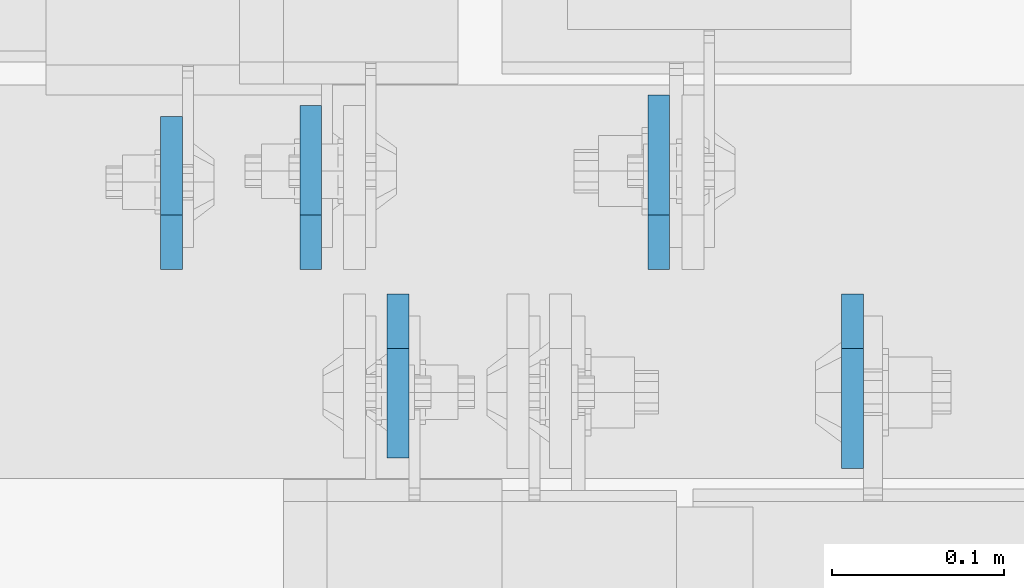
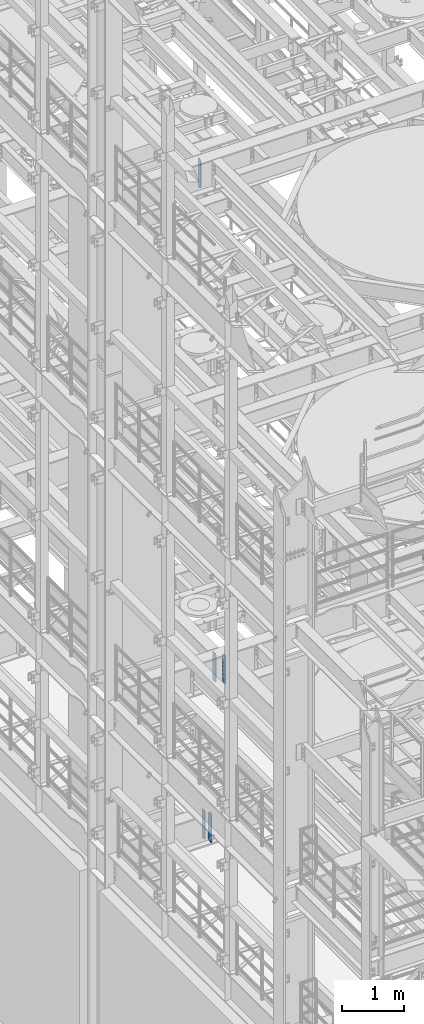
# One storey, part 1562 of 1876: 5 plates, 3 elements without a shape of their own.
"""IFC2X3 building model written with IfcOpenShell, lengths in millimetres."""

from ifc_helpers import new_model, si_unit, frame, origin_with_axes, place, context, subcontext, project, spatial, faceted_brep, material, type_object, element, aggregate, save


model = new_model("IFC2X3")

# Units and contexts
model_context = context("Model", 3, precision=1e-05, world=origin_with_axes())
body_context = subcontext(model_context, "Body", "Model", "MODEL_VIEW")
ifc_project = project(units=[si_unit("LENGTHUNIT", "METRE", prefix="MILLI"), si_unit("AREAUNIT", "SQUARE_METRE"), si_unit("VOLUMEUNIT", "CUBIC_METRE"), si_unit("MASSUNIT", "GRAM", prefix="KILO"), si_unit("TIMEUNIT", "SECOND"), si_unit("PLANEANGLEUNIT", "RADIAN"), si_unit("SOLIDANGLEUNIT", "STERADIAN"), si_unit("THERMODYNAMICTEMPERATUREUNIT", "DEGREE_CELSIUS"), si_unit("LUMINOUSINTENSITYUNIT", "LUMEN")], contexts=[model_context])

# Site, building, storey
site_placement = place(None, origin_with_axes())
site = spatial("IfcSite", under=ifc_project, at=site_placement, CompositionType="ELEMENT")
building_placement = place(site_placement, origin_with_axes())
building = spatial("IfcBuilding", under=site, at=building_placement, Name="Undefined", CompositionType="ELEMENT")
storey_placement = place(building_placement, origin_with_axes())
storey = spatial("IfcBuildingStorey", under=building, at=storey_placement, Name="Undefined", CompositionType="ELEMENT", Elevation=0.0)

# Assembly, plate
assembly_1_placement = place(storey_placement, origin_with_axes())
assembly_1 = element("IfcElementAssembly", 1, at=assembly_1_placement, inside=storey, Name="BEAM", AssemblyPlace="NOTDEFINED", PredefinedType="RIGID_FRAME")
ifc_material = material(Name="STEEL/A36")
plate_type_1 = type_object("IfcPlateType", PredefinedType="NOTDEFINED")
plate_1_placement = place(assembly_1_placement, frame((1789.11249990463, 1531.14375, 17386.3), z_axis=(0.0, 0.0, 1.0), x_axis=(0.0, 1.0, 0.0)))
plate_1 = element("IfcPlate", 2, at=plate_1_placement, type_object=plate_type_1, material=ifc_material, Name="PLATE", context=body_context, shape_type="Brep", body=[
    faceted_brep([(0.0, -6.34999999999991, 31.75), (0.0, -6.34999999999991, 539.75), (0.0, 6.34999999999991, 539.75), (0.0, 6.34999999999991, 31.75), (31.75, -6.34999999999991, 571.5), (31.75, 6.34999999999991, 571.5), (88.9000015258789, -6.34999999999991, 571.5), (88.9000015258789, 6.34999999999991, 571.5), (88.9000015258789, -6.34999999999991, 0.0), (88.9000015258789, 6.34999999999991, 0.0), (31.75, -6.34999999999991, 0.0), (31.75, 6.34999999999991, 0.0)], [[[0, 1, 2, 3]], [[1, 4, 5, 2]], [[4, 6, 7, 5]], [[6, 8, 9, 7]], [[8, 10, 11, 9]], [[10, 0, 3, 11]], [[5, 7, 9, 11, 3, 2]], [[10, 8, 6, 4, 1, 0]]]),
])
aggregate(assembly_1, [plate_1])

# Assembly, plates
assembly_2_placement = place(storey_placement, origin_with_axes())
assembly_2 = element("IfcElementAssembly", 3, at=assembly_2_placement, inside=storey, Name="BEAM", AssemblyPlace="NOTDEFINED", PredefinedType="RIGID_FRAME")
plate_type_2 = type_object("IfcPlateType", PredefinedType="NOTDEFINED")
plate_2_placement = place(assembly_2_placement, frame((1920.875, 1516.85625, 4535.4875), z_axis=(0.0, 0.0, 1.0), x_axis=(0.0, -1.0, 0.0)))
plate_2 = element("IfcPlate", 4, at=plate_2_placement, type_object=plate_type_2, material=ifc_material, Name="PLATE", context=body_context, shape_type="Brep", body=[
    faceted_brep([(0.0, -6.34999999999991, 31.75), (0.0, -6.35000000000036, 538.162475585938), (0.0, 6.35000000000036, 538.162475585938), (0.0, 6.34999999999991, 31.75), (31.75, -6.35000000000036, 569.912475585938), (31.75, 6.35000000000036, 569.912475585938), (95.25, -6.35000000000036, 569.912475585938), (95.25, 6.35000000000036, 569.912475585938), (95.25, -6.35000000000036, 0.0), (95.25, 6.35000000000036, 0.0), (31.75, -6.34999999999991, 0.0), (31.75, 6.34999999999991, 0.0)], [[[0, 1, 2, 3]], [[1, 4, 5, 2]], [[4, 6, 7, 5]], [[6, 8, 9, 7]], [[8, 10, 11, 9]], [[10, 0, 3, 11]], [[5, 7, 9, 11, 3, 2]], [[10, 8, 6, 4, 1, 0]]]),
])
plate_3_placement = place(assembly_2_placement, frame((1870.07499990463, 1531.14375, 4535.4875), z_axis=(0.0, 0.0, 1.0), x_axis=(0.0, 1.0, 0.0)))
plate_3 = element("IfcPlate", 5, at=plate_3_placement, type_object=plate_type_2, material=ifc_material, Name="PLATE", context=body_context, shape_type="Brep", body=[
    faceted_brep([(0.0, -6.34999999999991, 31.75), (0.0, -6.35000000000036, 538.162475585938), (0.0, 6.35000000000036, 538.162475585938), (0.0, 6.34999999999991, 31.75), (31.75, -6.35000000000036, 569.912475585938), (31.75, 6.35000000000036, 569.912475585938), (95.25, -6.35000000000036, 569.912475585938), (95.25, 6.35000000000036, 569.912475585938), (95.25, -6.35000000000036, 0.0), (95.25, 6.35000000000036, 0.0), (31.75, -6.34999999999991, 0.0), (31.75, 6.34999999999991, 0.0)], [[[0, 1, 2, 3]], [[1, 4, 5, 2]], [[4, 6, 7, 5]], [[6, 8, 9, 7]], [[8, 10, 11, 9]], [[10, 0, 3, 11]], [[5, 7, 9, 11, 3, 2]], [[10, 8, 6, 4, 1, 0]]]),
])
aggregate(assembly_2, [plate_2, plate_3])

assembly_3_placement = place(storey_placement, origin_with_axes())
assembly_3 = element("IfcElementAssembly", 6, at=assembly_3_placement, inside=storey, Name="BEAM", AssemblyPlace="NOTDEFINED", PredefinedType="RIGID_FRAME")
plate_type_3 = type_object("IfcPlateType", PredefinedType="NOTDEFINED")
plate_4_placement = place(assembly_3_placement, frame((2185.19374990463, 1516.85625, 7558.0875), z_axis=(0.0, 0.0, 1.0), x_axis=(0.0, -1.0, 0.0)))
plate_4 = element("IfcPlate", 7, at=plate_4_placement, type_object=plate_type_3, material=ifc_material, Name="PLATE", context=body_context, shape_type="Brep", body=[
    faceted_brep([(0.0, -6.34999999999991, 31.75), (0.0, -6.35000000000036, 538.162475585938), (0.0, 6.35000000000036, 538.162475585938), (0.0, 6.34999999999991, 31.75), (31.75, -6.35000000000036, 569.912475585938), (31.75, 6.35000000000036, 569.912475585938), (101.599998474121, -6.34999999999991, 569.912475585938), (101.599998474121, 6.34999999999991, 569.912475585938), (101.599998474121, -6.35000000000036, 0.0), (101.599998474121, 6.35000000000036, 0.0), (31.75, -6.34999999999991, 0.0), (31.75, 6.34999999999991, 0.0)], [[[0, 1, 2, 3]], [[1, 4, 5, 2]], [[4, 6, 7, 5]], [[6, 8, 9, 7]], [[8, 10, 11, 9]], [[10, 0, 3, 11]], [[5, 7, 9, 11, 3, 2]], [[10, 8, 6, 4, 1, 0]]]),
])
plate_5_placement = place(assembly_3_placement, frame((2072.48124990463, 1531.14375, 7558.0875), z_axis=(0.0, 0.0, 1.0), x_axis=(0.0, 1.0, 0.0)))
plate_5 = element("IfcPlate", 8, at=plate_5_placement, type_object=plate_type_3, material=ifc_material, Name="PLATE", context=body_context, shape_type="Brep", body=[
    faceted_brep([(0.0, -6.34999999999991, 31.75), (0.0, -6.35000000000036, 538.162475585938), (0.0, 6.35000000000036, 538.162475585938), (0.0, 6.34999999999991, 31.75), (31.75, -6.35000000000036, 569.912475585938), (31.75, 6.35000000000036, 569.912475585938), (101.599998474121, -6.34999999999991, 569.912475585938), (101.599998474121, 6.34999999999991, 569.912475585938), (101.599998474121, -6.35000000000036, 0.0), (101.599998474121, 6.35000000000036, 0.0), (31.75, -6.34999999999991, 0.0), (31.75, 6.34999999999991, 0.0)], [[[0, 1, 2, 3]], [[1, 4, 5, 2]], [[4, 6, 7, 5]], [[6, 8, 9, 7]], [[8, 10, 11, 9]], [[10, 0, 3, 11]], [[5, 7, 9, 11, 3, 2]], [[10, 8, 6, 4, 1, 0]]]),
])
aggregate(assembly_3, [plate_4, plate_5])

save(model, "model.ifc")
